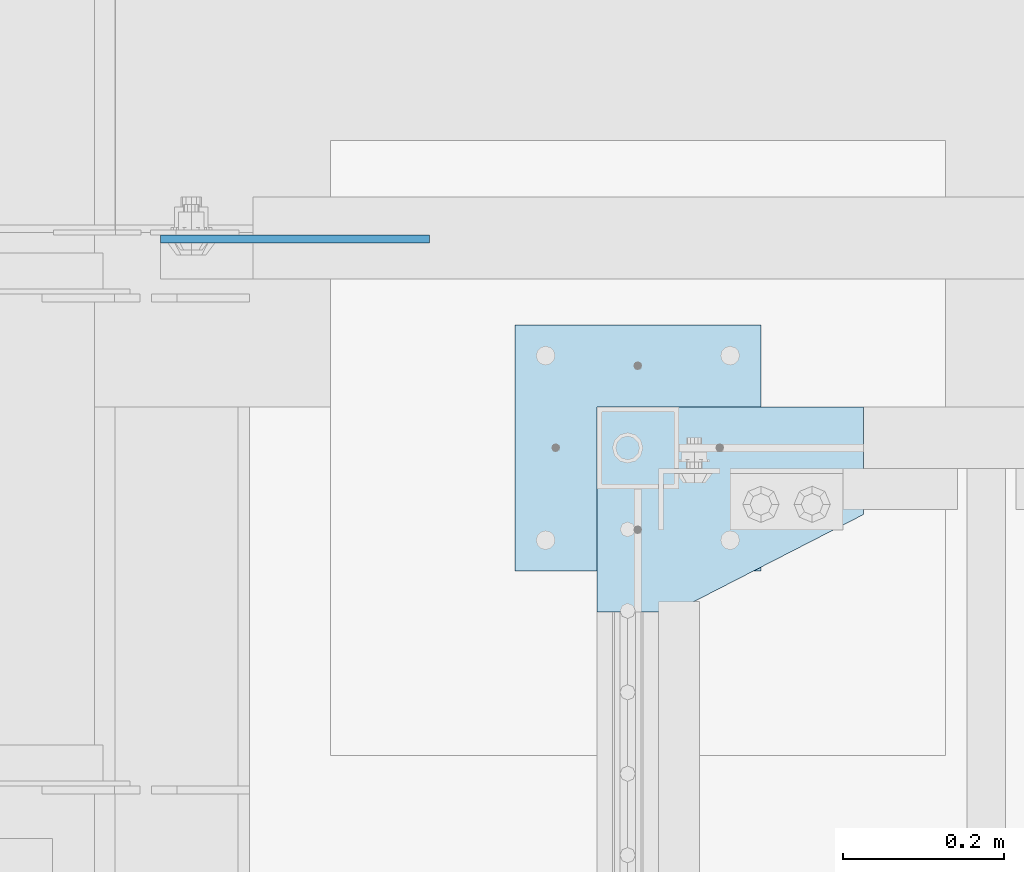
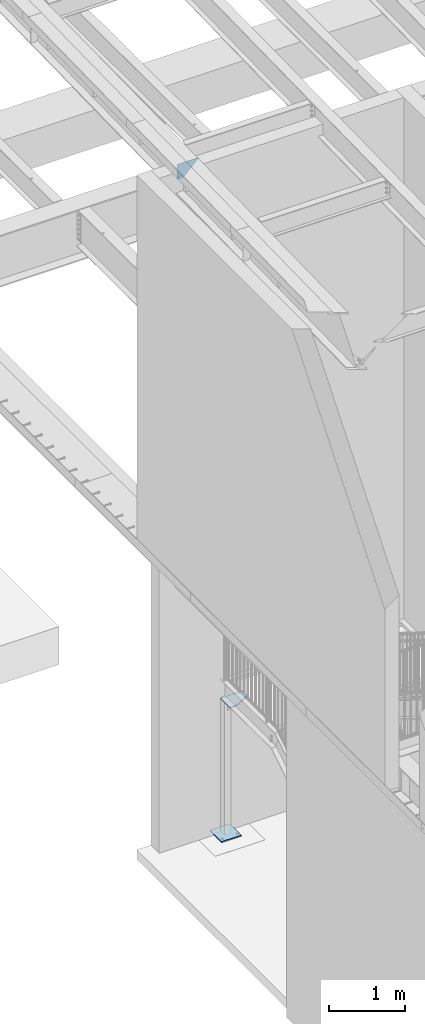
# One storey, part 1515 of 1763: 3 plates, 2 elements without a shape of their own.
"""IFC2X3 building model written with IfcOpenShell, lengths in millimetres."""

from ifc_helpers import new_model, si_unit, frame, origin_with_axes, place, context, subcontext, project, spatial, faceted_brep, material, type_object, element, aggregate, save


model = new_model("IFC2X3")

# Units and contexts
model_context = context("Model", 3, precision=1e-05, world=origin_with_axes())
body_context = subcontext(model_context, "Body", "Model", "MODEL_VIEW")
ifc_project = project(units=[si_unit("LENGTHUNIT", "METRE", prefix="MILLI"), si_unit("AREAUNIT", "SQUARE_METRE"), si_unit("VOLUMEUNIT", "CUBIC_METRE"), si_unit("MASSUNIT", "GRAM", prefix="KILO"), si_unit("TIMEUNIT", "SECOND"), si_unit("PLANEANGLEUNIT", "RADIAN"), si_unit("SOLIDANGLEUNIT", "STERADIAN"), si_unit("THERMODYNAMICTEMPERATUREUNIT", "DEGREE_CELSIUS"), si_unit("LUMINOUSINTENSITYUNIT", "LUMEN")], contexts=[model_context])

# Site, building, storey
site_placement = place(None, origin_with_axes())
site = spatial("IfcSite", under=ifc_project, at=site_placement, CompositionType="ELEMENT")
building_placement = place(site_placement, origin_with_axes())
building = spatial("IfcBuilding", under=site, at=building_placement, Name="Undefined", CompositionType="ELEMENT")
storey_placement = place(building_placement, origin_with_axes())
storey = spatial("IfcBuildingStorey", under=building, at=storey_placement, Name="Undefined", CompositionType="ELEMENT", Elevation=0.0)

# Assembly, plates
assembly_1_placement = place(storey_placement, origin_with_axes())
assembly_1 = element("IfcElementAssembly", 1, at=assembly_1_placement, inside=storey, Name="COLUMN", AssemblyPlace="NOTDEFINED", PredefinedType="RIGID_FRAME")
ifc_material = material(Name="STEEL/A36")
plate_type_1 = type_object("IfcPlateType", PredefinedType="NOTDEFINED")
plate_1_placement = place(assembly_1_placement, frame((-86918.2372736874, 37452.3, 314.32499999999), z_axis=(1.0, 0.0, 0.0), x_axis=(0.0, -1.0, 0.0)))
plate_1 = element("IfcPlate", 2, at=plate_1_placement, type_object=plate_type_1, material=ifc_material, Name="PLATE", context=body_context, shape_type="Brep", body=[
    faceted_brep([(0.0, -9.52500000000146, 0.0), (0.0, -9.52499999999998, 304.799987792969), (0.0, 9.52499999999998, 304.799987792969), (0.0, 9.52500000000146, 0.0), (304.799987792969, -9.52499999999998, 304.799987792969), (304.799987792969, 9.52499999999998, 304.799987792969), (304.799987792969, -9.52499999999998, 0.0), (304.799987792969, 9.52499999999998, 0.0)], [[[0, 1, 2, 3]], [[1, 4, 5, 2]], [[4, 6, 7, 5]], [[6, 0, 3, 7]], [[5, 7, 3, 2]], [[6, 4, 1, 0]]]),
])
plate_type_2 = type_object("IfcPlateType", PredefinedType="NOTDEFINED")
plate_2_placement = place(assembly_1_placement, frame((-86816.6372736874, 37350.7, 2473.325), z_axis=(1.0, 0.0, 0.0), x_axis=(0.0, -1.0, 0.0)))
plate_2 = element("IfcPlate", 3, at=plate_2_placement, type_object=plate_type_2, material=ifc_material, Name="PLATE", context=body_context, shape_type="Brep", body=[
    faceted_brep([(0.0, -4.76249999999982, 0.0), (0.0, -4.7625000000844, 330.200012206782), (0.0, 4.76249999994616, 330.200012206786), (0.0, 4.76249999999982, 0.0), (133.350006103516, -4.76249999999982, 330.199981689453), (133.350006103516, 4.76249999999982, 330.199981689453), (253.999984741211, -4.76249999999982, 95.25), (253.999984741211, 4.76249999999982, 95.25), (253.999984741211, -4.76249999999982, 0.0), (253.999984741211, 4.76249999999982, 0.0)], [[[0, 1, 2, 3]], [[1, 4, 5, 2]], [[4, 6, 7, 5]], [[6, 8, 9, 7]], [[8, 0, 3, 9]], [[5, 7, 9, 3, 2]], [[8, 6, 4, 1, 0]]]),
])
aggregate(assembly_1, [plate_1, plate_2])

# Assembly, plate
assembly_2_placement = place(storey_placement, origin_with_axes())
assembly_2 = element("IfcElementAssembly", 4, at=assembly_2_placement, inside=storey, Name="BEAM", AssemblyPlace="NOTDEFINED", PredefinedType="RIGID_FRAME")
plate_type_3 = type_object("IfcPlateType", PredefinedType="NOTDEFINED")
plate_3_placement = place(assembly_2_placement, frame((-87260.0435256352, 37558.6625080726, 10898.9636096628), z_axis=(-0.707106781186552, 0.0, 0.707106781186543), x_axis=(0.707106781186542, 0.0, 0.707106781186553)))
plate_3 = element("IfcPlate", 5, at=plate_3_placement, type_object=plate_type_3, material=ifc_material, Name="PLATE", context=body_context, shape_type="Brep", body=[
    faceted_brep([(0.0, -4.76249999999982, 0.0), (-68.6865768438074, -4.76249999999709, 68.6865844732238), (-68.6865768438074, 4.76249999999709, 68.6865844732238), (0.0, 4.76249999999982, 0.0), (98.2851104731089, -4.76249999999709, 235.658279419542), (98.2851104731089, 4.76249999999709, 235.658279419542), (333.943389893917, -4.76249999999709, -3.92901711165905e-10), (333.943389893917, 4.76249999999709, -3.92901711165905e-10)], [[[0, 1, 2, 3]], [[1, 4, 5, 2]], [[4, 6, 7, 5]], [[6, 0, 3, 7]], [[5, 7, 3, 2]], [[6, 4, 1, 0]]]),
])
aggregate(assembly_2, [plate_3])

save(model, "model.ifc")
